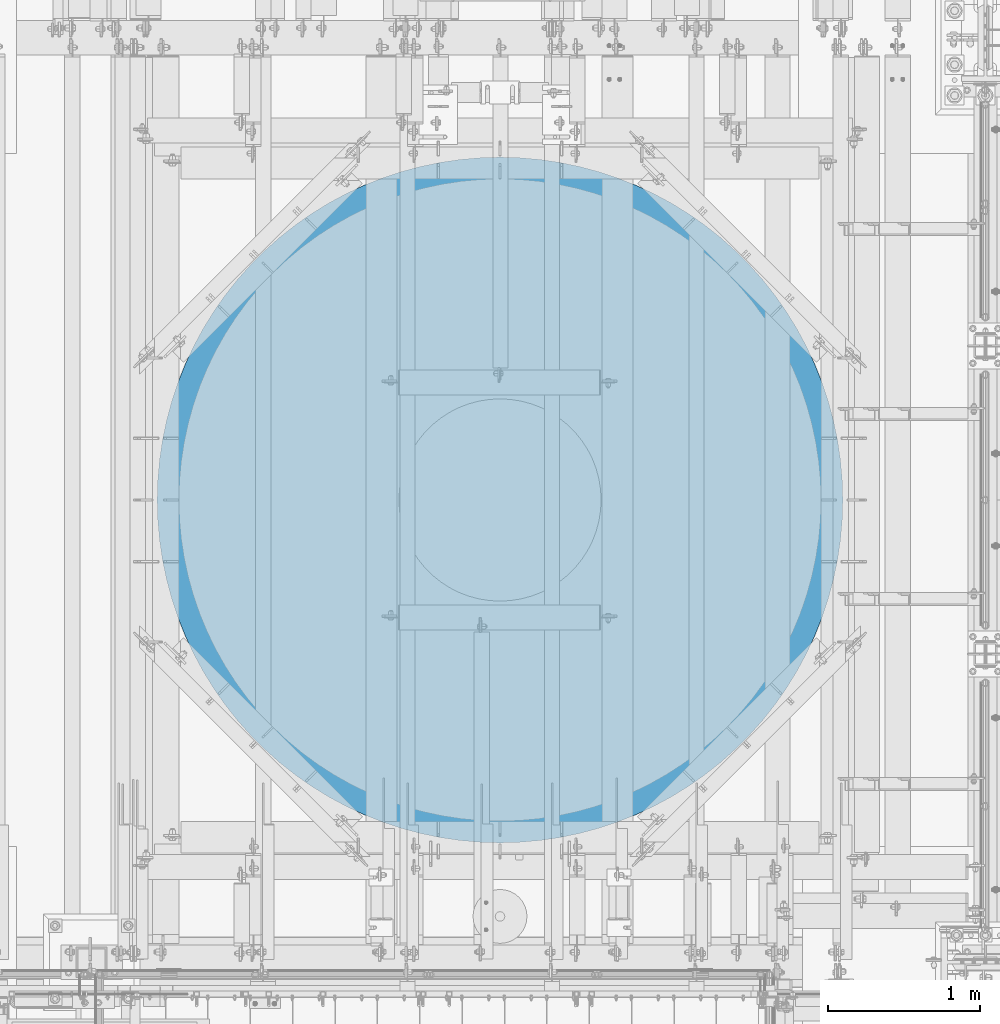
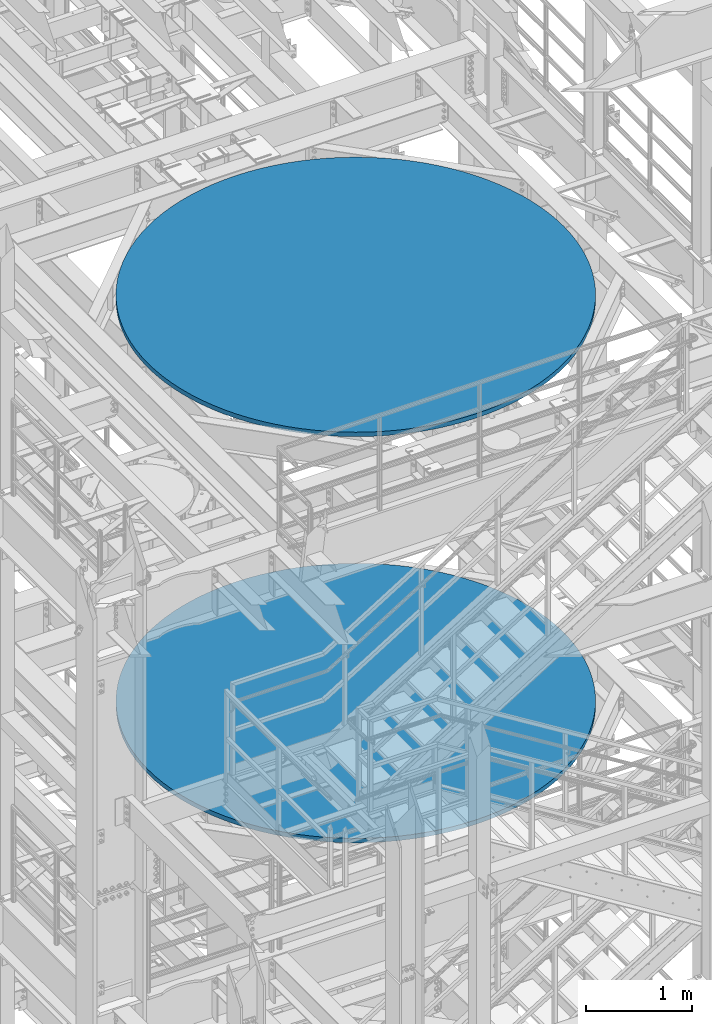
# One storey, part 689 of 1876: 2 columns, 2 elements without a shape of their own.
"""IFC2X3 building model written with IfcOpenShell, lengths in millimetres."""

from ifc_helpers import new_model, si_unit, frame, origin_with_axes, place, context, subcontext, project, spatial, faceted_brep, material, type_object, element, aggregate, save


model = new_model("IFC2X3")

# Units and contexts
model_context = context("Model", 3, precision=1e-05, world=origin_with_axes())
body_context = subcontext(model_context, "Body", "Model", "MODEL_VIEW")
ifc_project = project(units=[si_unit("LENGTHUNIT", "METRE", prefix="MILLI"), si_unit("AREAUNIT", "SQUARE_METRE"), si_unit("VOLUMEUNIT", "CUBIC_METRE"), si_unit("MASSUNIT", "GRAM", prefix="KILO"), si_unit("TIMEUNIT", "SECOND"), si_unit("PLANEANGLEUNIT", "RADIAN"), si_unit("SOLIDANGLEUNIT", "STERADIAN"), si_unit("THERMODYNAMICTEMPERATUREUNIT", "DEGREE_CELSIUS"), si_unit("LUMINOUSINTENSITYUNIT", "LUMEN")], contexts=[model_context])

# Site, building, storey
site_placement = place(None, origin_with_axes())
site = spatial("IfcSite", under=ifc_project, at=site_placement, CompositionType="ELEMENT")
building_placement = place(site_placement, origin_with_axes())
building = spatial("IfcBuilding", under=site, at=building_placement, Name="Undefined", CompositionType="ELEMENT")
storey_placement = place(building_placement, origin_with_axes())
storey = spatial("IfcBuildingStorey", under=building, at=storey_placement, Name="Undefined", CompositionType="ELEMENT", Elevation=0.0)

# Assembly, column
assembly_1_placement = place(storey_placement, origin_with_axes())
assembly_1 = element("IfcElementAssembly", 1, at=assembly_1_placement, inside=storey, Name="COLUMN", AssemblyPlace="NOTDEFINED", PredefinedType="REINFORCEMENT_UNIT")
ifc_material = material(Name="CONCRETE/3000")
column_type = type_object("IfcColumnType", PredefinedType="NOTDEFINED")
column_1_placement = place(assembly_1_placement, frame((4419.6, -1524.0, 17957.8), z_axis=(-1.0, 0.0, 0.0), x_axis=(0.0, 0.0, 1.0)))
column_1 = element("IfcColumn", 2, at=column_1_placement, type_object=column_type, material=ifc_material, Name="COLUMN", context=body_context, shape_type="Brep", body=[
    faceted_brep([(0.0, -2260.6, 0.0), (0.0, -2256.77542258803, -131.442200235023), (50.7999999999993, -2256.77542258803, -131.442200235023), (50.7999999999993, -2260.6, 0.0), (0.0, -2245.31463151144, -262.439641671495), (50.7999999999993, -2245.31463151144, -262.439641671495), (0.0, -2226.2564064594, -392.549070433863), (50.7999999999993, -2226.2564064594, -392.549070433863), (0.0, -2199.66523443275, -521.330237400361), (50.7999999999993, -2199.66523443275, -521.330237400361), (0.0, -2165.63109154039, -648.347387866692), (50.7999999999993, -2165.63109154039, -648.347387866692), (0.0, -2124.26913854862, -773.170736002006), (50.7999999999993, -2124.26913854862, -773.170736002006), (0.0, -2075.71933121355, -895.377919108118), (50.7999999999993, -2075.71933121355, -895.377919108118), (0.0, -2020.14594671511, -1014.55542676117), (50.7999999999993, -2020.14594671511, -1014.55542676117), (0.0, -1957.7370277951, -1130.3), (50.7999999999993, -1957.7370277951, -1130.3), (0.0, -1888.70374648008, -1242.21999582686), (50.7999999999993, -1888.70374648008, -1242.21999582686), (0.0, -1813.27968954205, -1349.93671240332), (50.7999999999993, -1813.27968954205, -1349.93671240332), (0.0, -1731.72006811476, -1453.08567045739), (50.7999999999993, -1731.72006811476, -1453.08567045739), (0.0, -1644.30085414003, -1551.31784656606), (50.7999999999993, -1644.30085414003, -1551.31784656606), (0.0, -1551.31784656606, -1644.30085414003), (50.7999999999993, -1551.31784656606, -1644.30085414003), (0.0, -1453.08567045739, -1731.72006811476), (50.7999999999993, -1453.08567045739, -1731.72006811476), (0.0, -1349.93671240332, -1813.27968954205), (50.7999999999993, -1349.93671240332, -1813.27968954205), (0.0, -1242.21999582686, -1888.70374648008), (50.7999999999993, -1242.21999582686, -1888.70374648008), (0.0, -1130.3, -1957.7370277951), (50.7999999999993, -1130.3, -1957.7370277951), (0.0, -1014.55542676116, -2020.14594671511), (50.7999999999993, -1014.55542676116, -2020.14594671511), (0.0, -895.377919108117, -2075.71933121355), (50.7999999999993, -895.377919108117, -2075.71933121355), (0.0, -773.170736002007, -2124.26913854862), (50.7999999999993, -773.170736002007, -2124.26913854862), (0.0, -648.347387866691, -2165.63109154039), (50.7999999999993, -648.347387866691, -2165.63109154039), (0.0, -521.33023740036, -2199.66523443275), (50.7999999999993, -521.33023740036, -2199.66523443275), (0.0, -392.549070433862, -2226.2564064594), (50.7999999999993, -392.549070433862, -2226.2564064594), (0.0, -262.439641671496, -2245.31463151144), (50.7999999999993, -262.439641671496, -2245.31463151144), (0.0, -131.442200235022, -2256.77542258803), (50.7999999999993, -131.442200235022, -2256.77542258803), (0.0, 4.54747350886464e-13, -2260.6), (50.7999999999993, 4.54747350886464e-13, -2260.6), (0.0, 131.442200235022, -2256.77542258803), (50.7999999999993, 131.442200235022, -2256.77542258803), (0.0, 262.439641671495, -2245.31463151144), (50.7999999999993, 262.439641671495, -2245.31463151144), (0.0, 392.549070433863, -2226.2564064594), (50.7999999999993, 392.549070433863, -2226.2564064594), (0.0, 521.330237400361, -2199.66523443275), (50.7999999999993, 521.330237400361, -2199.66523443275), (0.0, 648.347387866692, -2165.63109154039), (50.7999999999993, 648.347387866692, -2165.63109154039), (0.0, 773.170736002006, -2124.26913854863), (50.7999999999993, 773.170736002006, -2124.26913854863), (0.0, 895.377919108118, -2075.71933121355), (50.7999999999993, 895.377919108118, -2075.71933121355), (0.0, 1014.55542676117, -2020.14594671511), (50.7999999999993, 1014.55542676117, -2020.14594671511), (0.0, 1130.3, -1957.7370277951), (50.7999999999993, 1130.3, -1957.7370277951), (0.0, 1242.21999582686, -1888.70374648008), (50.7999999999993, 1242.21999582686, -1888.70374648008), (0.0, 1349.93671240332, -1813.27968954205), (50.7999999999993, 1349.93671240332, -1813.27968954205), (0.0, 1453.08567045739, -1731.72006811476), (50.7999999999993, 1453.08567045739, -1731.72006811476), (0.0, 1551.31784656606, -1644.30085414003), (50.7999999999993, 1551.31784656606, -1644.30085414003), (0.0, 1644.30085414003, -1551.31784656606), (50.7999999999993, 1644.30085414003, -1551.31784656606), (0.0, 1731.72006811476, -1453.08567045739), (50.7999999999993, 1731.72006811476, -1453.08567045739), (0.0, 1813.27968954205, -1349.93671240332), (50.7999999999993, 1813.27968954205, -1349.93671240332), (0.0, 1888.70374648008, -1242.21999582686), (50.7999999999993, 1888.70374648008, -1242.21999582686), (0.0, 1957.7370277951, -1130.3), (50.7999999999993, 1957.7370277951, -1130.3), (0.0, 2020.14594671511, -1014.55542676116), (50.7999999999993, 2020.14594671511, -1014.55542676116), (0.0, 2075.71933121355, -895.377919108118), (50.7999999999993, 2075.71933121355, -895.377919108118), (0.0, 2124.26913854862, -773.170736002006), (50.7999999999993, 2124.26913854862, -773.170736002006), (0.0, 2165.63109154039, -648.347387866691), (50.7999999999993, 2165.63109154039, -648.347387866691), (0.0, 2199.66523443275, -521.33023740036), (50.7999999999993, 2199.66523443275, -521.33023740036), (0.0, 2226.2564064594, -392.549070433863), (50.7999999999993, 2226.2564064594, -392.549070433863), (0.0, 2245.31463151144, -262.439641671495), (50.7999999999993, 2245.31463151144, -262.439641671495), (0.0, 2256.77542258803, -131.442200235022), (50.7999999999993, 2256.77542258803, -131.442200235022), (0.0, 2260.6, 0.0), (50.7999999999993, 2260.6, 0.0), (0.0, 2256.77542258803, 131.442200235021), (50.7999999999993, 2256.77542258803, 131.442200235021), (0.0, 2245.31463151144, 262.439641671495), (50.7999999999993, 2245.31463151144, 262.439641671495), (0.0, 2226.2564064594, 392.549070433863), (50.7999999999993, 2226.2564064594, 392.549070433863), (0.0, 2199.66523443275, 521.330237400361), (50.7999999999993, 2199.66523443275, 521.330237400361), (0.0, 2165.63109154039, 648.34738786669), (50.7999999999993, 2165.63109154039, 648.34738786669), (0.0, 2124.26913854862, 773.170736002007), (50.7999999999993, 2124.26913854862, 773.170736002007), (0.0, 2075.71933121355, 895.377919108118), (50.7999999999993, 2075.71933121355, 895.377919108118), (0.0, 2020.14594671511, 1014.55542676117), (50.7999999999993, 2020.14594671511, 1014.55542676117), (0.0, 1957.7370277951, 1130.3), (50.7999999999993, 1957.7370277951, 1130.3), (0.0, 1888.70374648008, 1242.21999582686), (50.7999999999993, 1888.70374648008, 1242.21999582686), (0.0, 1813.27968954205, 1349.93671240332), (50.7999999999993, 1813.27968954205, 1349.93671240332), (0.0, 1731.72006811476, 1453.08567045739), (50.7999999999993, 1731.72006811476, 1453.08567045739), (0.0, 1644.30085414003, 1551.31784656606), (50.7999999999993, 1644.30085414003, 1551.31784656606), (0.0, 1551.31784656606, 1644.30085414003), (50.7999999999993, 1551.31784656606, 1644.30085414003), (0.0, 1453.08567045739, 1731.72006811476), (50.7999999999993, 1453.08567045739, 1731.72006811476), (0.0, 1349.93671240332, 1813.27968954205), (50.7999999999993, 1349.93671240332, 1813.27968954205), (0.0, 1242.21999582686, 1888.70374648008), (50.7999999999993, 1242.21999582686, 1888.70374648008), (0.0, 1130.3, 1957.7370277951), (50.7999999999993, 1130.3, 1957.7370277951), (0.0, 1014.55542676116, 2020.14594671511), (50.7999999999993, 1014.55542676116, 2020.14594671511), (0.0, 895.377919108118, 2075.71933121355), (50.7999999999993, 895.377919108118, 2075.71933121355), (0.0, 773.170736002007, 2124.26913854862), (50.7999999999993, 773.170736002007, 2124.26913854862), (0.0, 648.34738786669, 2165.63109154039), (50.7999999999993, 648.34738786669, 2165.63109154039), (0.0, 521.33023740036, 2199.66523443275), (50.7999999999993, 521.33023740036, 2199.66523443275), (0.0, 392.549070433863, 2226.2564064594), (50.7999999999993, 392.549070433863, 2226.2564064594), (0.0, 262.439641671495, 2245.31463151144), (50.7999999999993, 262.439641671495, 2245.31463151144), (0.0, 131.442200235022, 2256.77542258803), (50.7999999999993, 131.442200235022, 2256.77542258803), (0.0, -2.27373675443232e-13, 2260.6), (50.7999999999993, -2.27373675443232e-13, 2260.6), (0.0, -131.442200235022, 2256.77542258803), (50.7999999999993, -131.442200235022, 2256.77542258803), (0.0, -262.439641671496, 2245.31463151144), (50.7999999999993, -262.439641671496, 2245.31463151144), (0.0, -392.549070433863, 2226.2564064594), (50.7999999999993, -392.549070433863, 2226.2564064594), (0.0, -521.33023740036, 2199.66523443275), (50.7999999999993, -521.33023740036, 2199.66523443275), (0.0, -648.347387866691, 2165.63109154039), (50.7999999999993, -648.347387866691, 2165.63109154039), (0.0, -773.170736002007, 2124.26913854862), (50.7999999999993, -773.170736002007, 2124.26913854862), (0.0, -895.377919108118, 2075.71933121355), (50.7999999999993, -895.377919108118, 2075.71933121355), (0.0, -1014.55542676117, 2020.14594671511), (50.7999999999993, -1014.55542676117, 2020.14594671511), (0.0, -1130.3, 1957.7370277951), (50.7999999999993, -1130.3, 1957.7370277951), (0.0, -1242.21999582686, 1888.70374648008), (50.7999999999993, -1242.21999582686, 1888.70374648008), (0.0, -1349.93671240332, 1813.27968954205), (50.7999999999993, -1349.93671240332, 1813.27968954205), (0.0, -1453.08567045739, 1731.72006811476), (50.7999999999993, -1453.08567045739, 1731.72006811476), (0.0, -1551.31784656606, 1644.30085414003), (50.7999999999993, -1551.31784656606, 1644.30085414003), (0.0, -1644.30085414003, 1551.31784656606), (50.7999999999993, -1644.30085414003, 1551.31784656606), (0.0, -1731.72006811476, 1453.08567045739), (50.7999999999993, -1731.72006811476, 1453.08567045739), (0.0, -1813.27968954205, 1349.93671240332), (50.7999999999993, -1813.27968954205, 1349.93671240332), (0.0, -1888.70374648008, 1242.21999582686), (50.7999999999993, -1888.70374648008, 1242.21999582686), (0.0, -1957.7370277951, 1130.3), (50.7999999999993, -1957.7370277951, 1130.3), (0.0, -2020.14594671511, 1014.55542676116), (50.7999999999993, -2020.14594671511, 1014.55542676116), (0.0, -2075.71933121355, 895.377919108118), (50.7999999999993, -2075.71933121355, 895.377919108118), (0.0, -2124.26913854862, 773.170736002006), (50.7999999999993, -2124.26913854862, 773.170736002006), (0.0, -2165.63109154039, 648.34738786669), (50.7999999999993, -2165.63109154039, 648.34738786669), (0.0, -2199.66523443275, 521.33023740036), (50.7999999999993, -2199.66523443275, 521.33023740036), (0.0, -2226.2564064594, 392.549070433863), (50.7999999999993, -2226.2564064594, 392.549070433863), (0.0, -2245.31463151144, 262.439641671495), (50.7999999999993, -2245.31463151144, 262.439641671495), (0.0, -2256.77542258803, 131.442200235022), (50.7999999999993, -2256.77542258803, 131.442200235022)], [[[0, 1, 2, 3]], [[1, 4, 5, 2]], [[4, 6, 7, 5]], [[6, 8, 9, 7]], [[8, 10, 11, 9]], [[10, 12, 13, 11]], [[12, 14, 15, 13]], [[14, 16, 17, 15]], [[16, 18, 19, 17]], [[18, 20, 21, 19]], [[20, 22, 23, 21]], [[22, 24, 25, 23]], [[24, 26, 27, 25]], [[26, 28, 29, 27]], [[28, 30, 31, 29]], [[30, 32, 33, 31]], [[32, 34, 35, 33]], [[34, 36, 37, 35]], [[36, 38, 39, 37]], [[38, 40, 41, 39]], [[40, 42, 43, 41]], [[42, 44, 45, 43]], [[44, 46, 47, 45]], [[46, 48, 49, 47]], [[48, 50, 51, 49]], [[50, 52, 53, 51]], [[52, 54, 55, 53]], [[54, 56, 57, 55]], [[56, 58, 59, 57]], [[58, 60, 61, 59]], [[60, 62, 63, 61]], [[62, 64, 65, 63]], [[64, 66, 67, 65]], [[66, 68, 69, 67]], [[68, 70, 71, 69]], [[70, 72, 73, 71]], [[72, 74, 75, 73]], [[74, 76, 77, 75]], [[76, 78, 79, 77]], [[78, 80, 81, 79]], [[80, 82, 83, 81]], [[82, 84, 85, 83]], [[84, 86, 87, 85]], [[86, 88, 89, 87]], [[88, 90, 91, 89]], [[90, 92, 93, 91]], [[92, 94, 95, 93]], [[94, 96, 97, 95]], [[96, 98, 99, 97]], [[98, 100, 101, 99]], [[100, 102, 103, 101]], [[102, 104, 105, 103]], [[104, 106, 107, 105]], [[106, 108, 109, 107]], [[108, 110, 111, 109]], [[110, 112, 113, 111]], [[112, 114, 115, 113]], [[114, 116, 117, 115]], [[116, 118, 119, 117]], [[118, 120, 121, 119]], [[120, 122, 123, 121]], [[122, 124, 125, 123]], [[124, 126, 127, 125]], [[126, 128, 129, 127]], [[128, 130, 131, 129]], [[130, 132, 133, 131]], [[132, 134, 135, 133]], [[134, 136, 137, 135]], [[136, 138, 139, 137]], [[138, 140, 141, 139]], [[140, 142, 143, 141]], [[142, 144, 145, 143]], [[144, 146, 147, 145]], [[146, 148, 149, 147]], [[148, 150, 151, 149]], [[150, 152, 153, 151]], [[152, 154, 155, 153]], [[154, 156, 157, 155]], [[156, 158, 159, 157]], [[158, 160, 161, 159]], [[160, 162, 163, 161]], [[162, 164, 165, 163]], [[164, 166, 167, 165]], [[166, 168, 169, 167]], [[168, 170, 171, 169]], [[170, 172, 173, 171]], [[172, 174, 175, 173]], [[174, 176, 177, 175]], [[176, 178, 179, 177]], [[178, 180, 181, 179]], [[180, 182, 183, 181]], [[182, 184, 185, 183]], [[184, 186, 187, 185]], [[186, 188, 189, 187]], [[188, 190, 191, 189]], [[190, 192, 193, 191]], [[192, 194, 195, 193]], [[194, 196, 197, 195]], [[196, 198, 199, 197]], [[198, 200, 201, 199]], [[200, 202, 203, 201]], [[202, 204, 205, 203]], [[204, 206, 207, 205]], [[206, 208, 209, 207]], [[208, 210, 211, 209]], [[210, 212, 213, 211]], [[212, 214, 215, 213]], [[214, 0, 3, 215]], [[5, 7, 9, 11, 13, 15, 17, 19, 21, 23, 25, 27, 29, 31, 33, 35, 37, 39, 41, 43, 45, 47, 49, 51, 53, 55, 57, 59, 61, 63, 65, 67, 69, 71, 73, 75, 77, 79, 81, 83, 85, 87, 89, 91, 93, 95, 97, 99, 101, 103, 105, 107, 109, 111, 113, 115, 117, 119, 121, 123, 125, 127, 129, 131, 133, 135, 137, 139, 141, 143, 145, 147, 149, 151, 153, 155, 157, 159, 161, 163, 165, 167, 169, 171, 173, 175, 177, 179, 181, 183, 185, 187, 189, 191, 193, 195, 197, 199, 201, 203, 205, 207, 209, 211, 213, 215, 3, 2]], [[214, 212, 210, 208, 206, 204, 202, 200, 198, 196, 194, 192, 190, 188, 186, 184, 182, 180, 178, 176, 174, 172, 170, 168, 166, 164, 162, 160, 158, 156, 154, 152, 150, 148, 146, 144, 142, 140, 138, 136, 134, 132, 130, 128, 126, 124, 122, 120, 118, 116, 114, 112, 110, 108, 106, 104, 102, 100, 98, 96, 94, 92, 90, 88, 86, 84, 82, 80, 78, 76, 74, 72, 70, 68, 66, 64, 62, 60, 58, 56, 54, 52, 50, 48, 46, 44, 42, 40, 38, 36, 34, 32, 30, 28, 26, 24, 22, 20, 18, 16, 14, 12, 10, 8, 6, 4, 1, 0]]]),
])
aggregate(assembly_1, [column_1])

assembly_2_placement = place(storey_placement, origin_with_axes())
assembly_2 = element("IfcElementAssembly", 3, at=assembly_2_placement, inside=storey, Name="COLUMN", AssemblyPlace="NOTDEFINED", PredefinedType="REINFORCEMENT_UNIT")
column_2_placement = place(assembly_2_placement, frame((4419.6, -1524.0, 13284.2), z_axis=(-1.0, 0.0, 0.0), x_axis=(0.0, 0.0, 1.0)))
column_2 = element("IfcColumn", 4, at=column_2_placement, type_object=column_type, material=ifc_material, Name="COLUMN", context=body_context, shape_type="Brep", body=[
    faceted_brep([(0.0, -2260.6, 0.0), (0.0, -2256.77542258803, -131.442200235023), (50.7999999999993, -2256.77542258803, -131.442200235023), (50.7999999999993, -2260.6, 0.0), (0.0, -2245.31463151144, -262.439641671495), (50.7999999999993, -2245.31463151144, -262.439641671495), (0.0, -2226.2564064594, -392.549070433863), (50.7999999999993, -2226.2564064594, -392.549070433863), (0.0, -2199.66523443275, -521.330237400361), (50.7999999999993, -2199.66523443275, -521.330237400361), (0.0, -2165.63109154039, -648.347387866692), (50.7999999999993, -2165.63109154039, -648.347387866692), (0.0, -2124.26913854862, -773.170736002006), (50.7999999999993, -2124.26913854862, -773.170736002006), (0.0, -2075.71933121355, -895.377919108118), (50.7999999999993, -2075.71933121355, -895.377919108118), (0.0, -2020.14594671511, -1014.55542676117), (50.7999999999993, -2020.14594671511, -1014.55542676117), (0.0, -1957.7370277951, -1130.3), (50.7999999999993, -1957.7370277951, -1130.3), (0.0, -1888.70374648008, -1242.21999582686), (50.7999999999993, -1888.70374648008, -1242.21999582686), (0.0, -1813.27968954205, -1349.93671240332), (50.7999999999993, -1813.27968954205, -1349.93671240332), (0.0, -1731.72006811476, -1453.08567045739), (50.7999999999993, -1731.72006811476, -1453.08567045739), (0.0, -1644.30085414003, -1551.31784656606), (50.7999999999993, -1644.30085414003, -1551.31784656606), (0.0, -1551.31784656606, -1644.30085414003), (50.7999999999993, -1551.31784656606, -1644.30085414003), (0.0, -1453.08567045739, -1731.72006811476), (50.7999999999993, -1453.08567045739, -1731.72006811476), (0.0, -1349.93671240332, -1813.27968954205), (50.7999999999993, -1349.93671240332, -1813.27968954205), (0.0, -1242.21999582686, -1888.70374648008), (50.7999999999993, -1242.21999582686, -1888.70374648008), (0.0, -1130.3, -1957.7370277951), (50.7999999999993, -1130.3, -1957.7370277951), (0.0, -1014.55542676116, -2020.14594671511), (50.7999999999993, -1014.55542676116, -2020.14594671511), (0.0, -895.377919108117, -2075.71933121355), (50.7999999999993, -895.377919108117, -2075.71933121355), (0.0, -773.170736002007, -2124.26913854862), (50.7999999999993, -773.170736002007, -2124.26913854862), (0.0, -648.347387866691, -2165.63109154039), (50.7999999999993, -648.347387866691, -2165.63109154039), (0.0, -521.33023740036, -2199.66523443275), (50.7999999999993, -521.33023740036, -2199.66523443275), (0.0, -392.549070433862, -2226.2564064594), (50.7999999999993, -392.549070433862, -2226.2564064594), (0.0, -262.439641671496, -2245.31463151144), (50.7999999999993, -262.439641671496, -2245.31463151144), (0.0, -131.442200235022, -2256.77542258803), (50.7999999999993, -131.442200235022, -2256.77542258803), (0.0, 4.54747350886464e-13, -2260.6), (50.7999999999993, 4.54747350886464e-13, -2260.6), (0.0, 131.442200235022, -2256.77542258803), (50.7999999999993, 131.442200235022, -2256.77542258803), (0.0, 262.439641671495, -2245.31463151144), (50.7999999999993, 262.439641671495, -2245.31463151144), (0.0, 392.549070433863, -2226.2564064594), (50.7999999999993, 392.549070433863, -2226.2564064594), (0.0, 521.330237400361, -2199.66523443275), (50.7999999999993, 521.330237400361, -2199.66523443275), (0.0, 648.347387866692, -2165.63109154039), (50.7999999999993, 648.347387866692, -2165.63109154039), (0.0, 773.170736002006, -2124.26913854863), (50.7999999999993, 773.170736002006, -2124.26913854863), (0.0, 895.377919108118, -2075.71933121355), (50.7999999999993, 895.377919108118, -2075.71933121355), (0.0, 1014.55542676117, -2020.14594671511), (50.7999999999993, 1014.55542676117, -2020.14594671511), (0.0, 1130.3, -1957.7370277951), (50.7999999999993, 1130.3, -1957.7370277951), (0.0, 1242.21999582686, -1888.70374648008), (50.7999999999993, 1242.21999582686, -1888.70374648008), (0.0, 1349.93671240332, -1813.27968954205), (50.7999999999993, 1349.93671240332, -1813.27968954205), (0.0, 1453.08567045739, -1731.72006811476), (50.7999999999993, 1453.08567045739, -1731.72006811476), (0.0, 1551.31784656606, -1644.30085414003), (50.7999999999993, 1551.31784656606, -1644.30085414003), (0.0, 1644.30085414003, -1551.31784656606), (50.7999999999993, 1644.30085414003, -1551.31784656606), (0.0, 1731.72006811476, -1453.08567045739), (50.7999999999993, 1731.72006811476, -1453.08567045739), (0.0, 1813.27968954205, -1349.93671240332), (50.7999999999993, 1813.27968954205, -1349.93671240332), (0.0, 1888.70374648008, -1242.21999582686), (50.7999999999993, 1888.70374648008, -1242.21999582686), (0.0, 1957.7370277951, -1130.3), (50.7999999999993, 1957.7370277951, -1130.3), (0.0, 2020.14594671511, -1014.55542676116), (50.7999999999993, 2020.14594671511, -1014.55542676116), (0.0, 2075.71933121355, -895.377919108118), (50.7999999999993, 2075.71933121355, -895.377919108118), (0.0, 2124.26913854862, -773.170736002006), (50.7999999999993, 2124.26913854862, -773.170736002006), (0.0, 2165.63109154039, -648.347387866691), (50.7999999999993, 2165.63109154039, -648.347387866691), (0.0, 2199.66523443275, -521.33023740036), (50.7999999999993, 2199.66523443275, -521.33023740036), (0.0, 2226.2564064594, -392.549070433863), (50.7999999999993, 2226.2564064594, -392.549070433863), (0.0, 2245.31463151144, -262.439641671495), (50.7999999999993, 2245.31463151144, -262.439641671495), (0.0, 2256.77542258803, -131.442200235022), (50.7999999999993, 2256.77542258803, -131.442200235022), (0.0, 2260.6, 0.0), (50.7999999999993, 2260.6, 0.0), (0.0, 2256.77542258803, 131.442200235021), (50.7999999999993, 2256.77542258803, 131.442200235021), (0.0, 2245.31463151144, 262.439641671495), (50.7999999999993, 2245.31463151144, 262.439641671495), (0.0, 2226.2564064594, 392.549070433863), (50.7999999999993, 2226.2564064594, 392.549070433863), (0.0, 2199.66523443275, 521.330237400361), (50.7999999999993, 2199.66523443275, 521.330237400361), (0.0, 2165.63109154039, 648.34738786669), (50.7999999999993, 2165.63109154039, 648.34738786669), (0.0, 2124.26913854862, 773.170736002007), (50.7999999999993, 2124.26913854862, 773.170736002007), (0.0, 2075.71933121355, 895.377919108118), (50.7999999999993, 2075.71933121355, 895.377919108118), (0.0, 2020.14594671511, 1014.55542676117), (50.7999999999993, 2020.14594671511, 1014.55542676117), (0.0, 1957.7370277951, 1130.3), (50.7999999999993, 1957.7370277951, 1130.3), (0.0, 1888.70374648008, 1242.21999582686), (50.7999999999993, 1888.70374648008, 1242.21999582686), (0.0, 1813.27968954205, 1349.93671240332), (50.7999999999993, 1813.27968954205, 1349.93671240332), (0.0, 1731.72006811476, 1453.08567045739), (50.7999999999993, 1731.72006811476, 1453.08567045739), (0.0, 1644.30085414003, 1551.31784656606), (50.7999999999993, 1644.30085414003, 1551.31784656606), (0.0, 1551.31784656606, 1644.30085414003), (50.7999999999993, 1551.31784656606, 1644.30085414003), (0.0, 1453.08567045739, 1731.72006811476), (50.7999999999993, 1453.08567045739, 1731.72006811476), (0.0, 1349.93671240332, 1813.27968954205), (50.7999999999993, 1349.93671240332, 1813.27968954205), (0.0, 1242.21999582686, 1888.70374648008), (50.7999999999993, 1242.21999582686, 1888.70374648008), (0.0, 1130.3, 1957.7370277951), (50.7999999999993, 1130.3, 1957.7370277951), (0.0, 1014.55542676116, 2020.14594671511), (50.7999999999993, 1014.55542676116, 2020.14594671511), (0.0, 895.377919108118, 2075.71933121355), (50.7999999999993, 895.377919108118, 2075.71933121355), (0.0, 773.170736002007, 2124.26913854862), (50.7999999999993, 773.170736002007, 2124.26913854862), (0.0, 648.34738786669, 2165.63109154039), (50.7999999999993, 648.34738786669, 2165.63109154039), (0.0, 521.33023740036, 2199.66523443275), (50.7999999999993, 521.33023740036, 2199.66523443275), (0.0, 392.549070433863, 2226.2564064594), (50.7999999999993, 392.549070433863, 2226.2564064594), (0.0, 262.439641671495, 2245.31463151144), (50.7999999999993, 262.439641671495, 2245.31463151144), (0.0, 131.442200235022, 2256.77542258803), (50.7999999999993, 131.442200235022, 2256.77542258803), (0.0, -2.27373675443232e-13, 2260.6), (50.7999999999993, -2.27373675443232e-13, 2260.6), (0.0, -131.442200235022, 2256.77542258803), (50.7999999999993, -131.442200235022, 2256.77542258803), (0.0, -262.439641671496, 2245.31463151144), (50.7999999999993, -262.439641671496, 2245.31463151144), (0.0, -392.549070433863, 2226.2564064594), (50.7999999999993, -392.549070433863, 2226.2564064594), (0.0, -521.33023740036, 2199.66523443275), (50.7999999999993, -521.33023740036, 2199.66523443275), (0.0, -648.347387866691, 2165.63109154039), (50.7999999999993, -648.347387866691, 2165.63109154039), (0.0, -773.170736002007, 2124.26913854862), (50.7999999999993, -773.170736002007, 2124.26913854862), (0.0, -895.377919108118, 2075.71933121355), (50.7999999999993, -895.377919108118, 2075.71933121355), (0.0, -1014.55542676117, 2020.14594671511), (50.7999999999993, -1014.55542676117, 2020.14594671511), (0.0, -1130.3, 1957.7370277951), (50.7999999999993, -1130.3, 1957.7370277951), (0.0, -1242.21999582686, 1888.70374648008), (50.7999999999993, -1242.21999582686, 1888.70374648008), (0.0, -1349.93671240332, 1813.27968954205), (50.7999999999993, -1349.93671240332, 1813.27968954205), (0.0, -1453.08567045739, 1731.72006811476), (50.7999999999993, -1453.08567045739, 1731.72006811476), (0.0, -1551.31784656606, 1644.30085414003), (50.7999999999993, -1551.31784656606, 1644.30085414003), (0.0, -1644.30085414003, 1551.31784656606), (50.7999999999993, -1644.30085414003, 1551.31784656606), (0.0, -1731.72006811476, 1453.08567045739), (50.7999999999993, -1731.72006811476, 1453.08567045739), (0.0, -1813.27968954205, 1349.93671240332), (50.7999999999993, -1813.27968954205, 1349.93671240332), (0.0, -1888.70374648008, 1242.21999582686), (50.7999999999993, -1888.70374648008, 1242.21999582686), (0.0, -1957.7370277951, 1130.3), (50.7999999999993, -1957.7370277951, 1130.3), (0.0, -2020.14594671511, 1014.55542676116), (50.7999999999993, -2020.14594671511, 1014.55542676116), (0.0, -2075.71933121355, 895.377919108118), (50.7999999999993, -2075.71933121355, 895.377919108118), (0.0, -2124.26913854862, 773.170736002006), (50.7999999999993, -2124.26913854862, 773.170736002006), (0.0, -2165.63109154039, 648.34738786669), (50.7999999999993, -2165.63109154039, 648.34738786669), (0.0, -2199.66523443275, 521.33023740036), (50.7999999999993, -2199.66523443275, 521.33023740036), (0.0, -2226.2564064594, 392.549070433863), (50.7999999999993, -2226.2564064594, 392.549070433863), (0.0, -2245.31463151144, 262.439641671495), (50.7999999999993, -2245.31463151144, 262.439641671495), (0.0, -2256.77542258803, 131.442200235022), (50.7999999999993, -2256.77542258803, 131.442200235022)], [[[0, 1, 2, 3]], [[1, 4, 5, 2]], [[4, 6, 7, 5]], [[6, 8, 9, 7]], [[8, 10, 11, 9]], [[10, 12, 13, 11]], [[12, 14, 15, 13]], [[14, 16, 17, 15]], [[16, 18, 19, 17]], [[18, 20, 21, 19]], [[20, 22, 23, 21]], [[22, 24, 25, 23]], [[24, 26, 27, 25]], [[26, 28, 29, 27]], [[28, 30, 31, 29]], [[30, 32, 33, 31]], [[32, 34, 35, 33]], [[34, 36, 37, 35]], [[36, 38, 39, 37]], [[38, 40, 41, 39]], [[40, 42, 43, 41]], [[42, 44, 45, 43]], [[44, 46, 47, 45]], [[46, 48, 49, 47]], [[48, 50, 51, 49]], [[50, 52, 53, 51]], [[52, 54, 55, 53]], [[54, 56, 57, 55]], [[56, 58, 59, 57]], [[58, 60, 61, 59]], [[60, 62, 63, 61]], [[62, 64, 65, 63]], [[64, 66, 67, 65]], [[66, 68, 69, 67]], [[68, 70, 71, 69]], [[70, 72, 73, 71]], [[72, 74, 75, 73]], [[74, 76, 77, 75]], [[76, 78, 79, 77]], [[78, 80, 81, 79]], [[80, 82, 83, 81]], [[82, 84, 85, 83]], [[84, 86, 87, 85]], [[86, 88, 89, 87]], [[88, 90, 91, 89]], [[90, 92, 93, 91]], [[92, 94, 95, 93]], [[94, 96, 97, 95]], [[96, 98, 99, 97]], [[98, 100, 101, 99]], [[100, 102, 103, 101]], [[102, 104, 105, 103]], [[104, 106, 107, 105]], [[106, 108, 109, 107]], [[108, 110, 111, 109]], [[110, 112, 113, 111]], [[112, 114, 115, 113]], [[114, 116, 117, 115]], [[116, 118, 119, 117]], [[118, 120, 121, 119]], [[120, 122, 123, 121]], [[122, 124, 125, 123]], [[124, 126, 127, 125]], [[126, 128, 129, 127]], [[128, 130, 131, 129]], [[130, 132, 133, 131]], [[132, 134, 135, 133]], [[134, 136, 137, 135]], [[136, 138, 139, 137]], [[138, 140, 141, 139]], [[140, 142, 143, 141]], [[142, 144, 145, 143]], [[144, 146, 147, 145]], [[146, 148, 149, 147]], [[148, 150, 151, 149]], [[150, 152, 153, 151]], [[152, 154, 155, 153]], [[154, 156, 157, 155]], [[156, 158, 159, 157]], [[158, 160, 161, 159]], [[160, 162, 163, 161]], [[162, 164, 165, 163]], [[164, 166, 167, 165]], [[166, 168, 169, 167]], [[168, 170, 171, 169]], [[170, 172, 173, 171]], [[172, 174, 175, 173]], [[174, 176, 177, 175]], [[176, 178, 179, 177]], [[178, 180, 181, 179]], [[180, 182, 183, 181]], [[182, 184, 185, 183]], [[184, 186, 187, 185]], [[186, 188, 189, 187]], [[188, 190, 191, 189]], [[190, 192, 193, 191]], [[192, 194, 195, 193]], [[194, 196, 197, 195]], [[196, 198, 199, 197]], [[198, 200, 201, 199]], [[200, 202, 203, 201]], [[202, 204, 205, 203]], [[204, 206, 207, 205]], [[206, 208, 209, 207]], [[208, 210, 211, 209]], [[210, 212, 213, 211]], [[212, 214, 215, 213]], [[214, 0, 3, 215]], [[5, 7, 9, 11, 13, 15, 17, 19, 21, 23, 25, 27, 29, 31, 33, 35, 37, 39, 41, 43, 45, 47, 49, 51, 53, 55, 57, 59, 61, 63, 65, 67, 69, 71, 73, 75, 77, 79, 81, 83, 85, 87, 89, 91, 93, 95, 97, 99, 101, 103, 105, 107, 109, 111, 113, 115, 117, 119, 121, 123, 125, 127, 129, 131, 133, 135, 137, 139, 141, 143, 145, 147, 149, 151, 153, 155, 157, 159, 161, 163, 165, 167, 169, 171, 173, 175, 177, 179, 181, 183, 185, 187, 189, 191, 193, 195, 197, 199, 201, 203, 205, 207, 209, 211, 213, 215, 3, 2]], [[214, 212, 210, 208, 206, 204, 202, 200, 198, 196, 194, 192, 190, 188, 186, 184, 182, 180, 178, 176, 174, 172, 170, 168, 166, 164, 162, 160, 158, 156, 154, 152, 150, 148, 146, 144, 142, 140, 138, 136, 134, 132, 130, 128, 126, 124, 122, 120, 118, 116, 114, 112, 110, 108, 106, 104, 102, 100, 98, 96, 94, 92, 90, 88, 86, 84, 82, 80, 78, 76, 74, 72, 70, 68, 66, 64, 62, 60, 58, 56, 54, 52, 50, 48, 46, 44, 42, 40, 38, 36, 34, 32, 30, 28, 26, 24, 22, 20, 18, 16, 14, 12, 10, 8, 6, 4, 1, 0]]]),
])
aggregate(assembly_2, [column_2])

save(model, "model.ifc")
